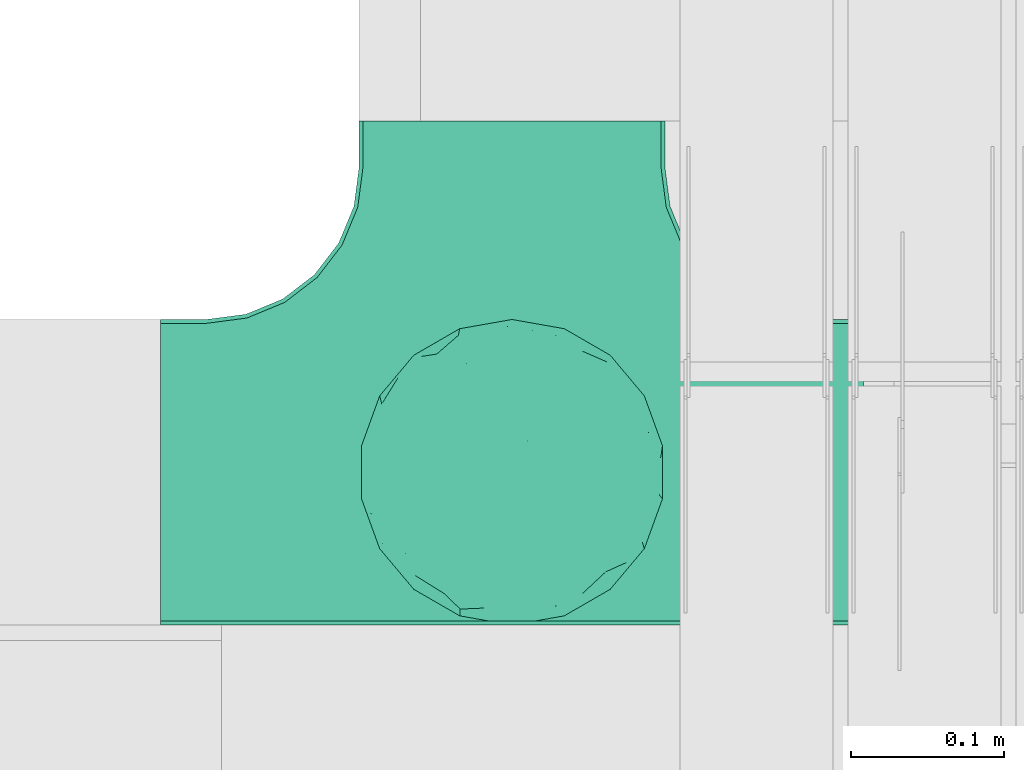
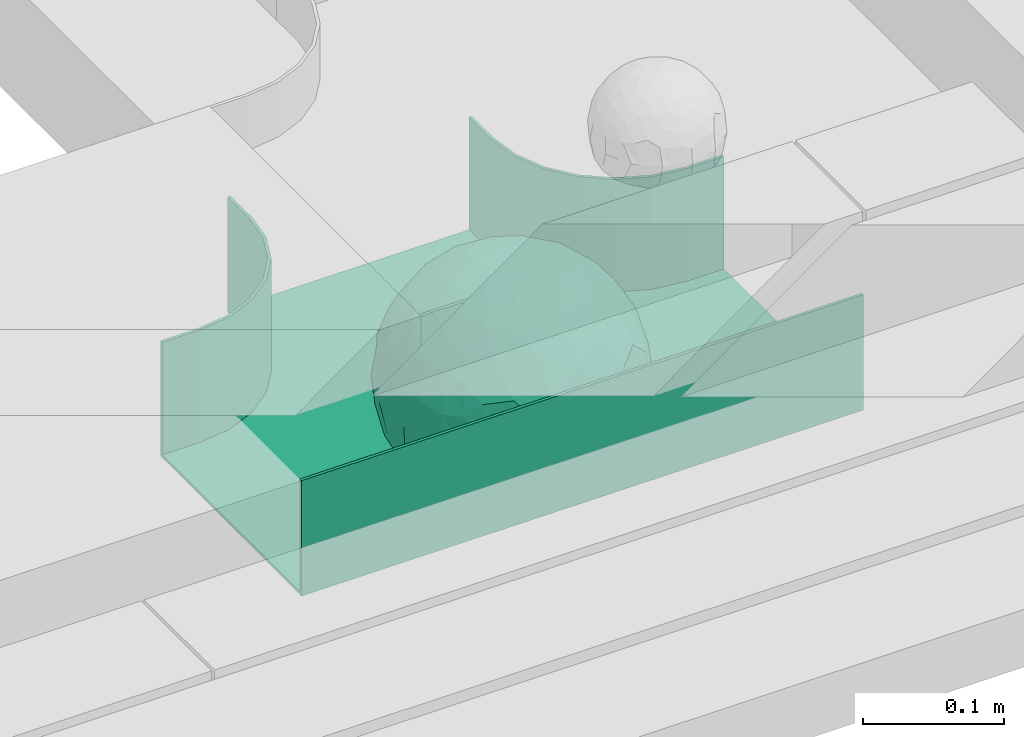
# One storey, part 31 of 33: 1 flow fitting.
"""IFC2X3 building model written with IfcOpenShell, lengths in millimetres."""

from ifc_helpers import new_model, entity, si_unit, converted_unit, derived_unit, direction, frame, origin, place, context, subcontext, project, spatial, faceted_brep, source, transform, mapped, material, material_list, type_object, type_shapes, element, save


model = new_model("IFC2X3")

# Units and contexts
model_context = context("Model", 3, precision=0.01, world=origin(), true_north=direction((6.12303176911189e-17, 1.0)))
body_context = subcontext(model_context, "Body", "Model", "MODEL_VIEW")
ifc_project = project(units=[si_unit("LENGTHUNIT", "METRE", prefix="MILLI"), si_unit("AREAUNIT", "SQUARE_METRE"), si_unit("VOLUMEUNIT", "CUBIC_METRE"), converted_unit("PLANEANGLEUNIT", "DEGREE", entity("IfcRatioMeasure", 0.0174532925199433), si_unit("PLANEANGLEUNIT", "RADIAN"), dimensions=[0, 0, 0, 0, 0, 0, 0]), si_unit("MASSUNIT", "GRAM", prefix="KILO"), derived_unit("MASSDENSITYUNIT", [(si_unit("MASSUNIT", "GRAM", prefix="KILO"), 1), (si_unit("LENGTHUNIT", "METRE"), -3)]), derived_unit("MOMENTOFINERTIAUNIT", [(si_unit("LENGTHUNIT", "METRE"), 4)]), si_unit("TIMEUNIT", "SECOND"), si_unit("FREQUENCYUNIT", "HERTZ"), si_unit("THERMODYNAMICTEMPERATUREUNIT", "DEGREE_CELSIUS"), derived_unit("THERMALTRANSMITTANCEUNIT", [(si_unit("MASSUNIT", "GRAM", prefix="KILO"), 1), (si_unit("THERMODYNAMICTEMPERATUREUNIT", "KELVIN"), -1), (si_unit("TIMEUNIT", "SECOND"), -3)]), derived_unit("VOLUMETRICFLOWRATEUNIT", [(si_unit("LENGTHUNIT", "METRE"), 3), (si_unit("TIMEUNIT", "SECOND"), -1)]), derived_unit("MASSFLOWRATEUNIT", [(si_unit("MASSUNIT", "GRAM", prefix="KILO"), 1), (si_unit("TIMEUNIT", "SECOND"), -1)]), derived_unit("ROTATIONALFREQUENCYUNIT", [(si_unit("TIMEUNIT", "SECOND"), -1)]), si_unit("ELECTRICCURRENTUNIT", "AMPERE"), si_unit("ELECTRICVOLTAGEUNIT", "VOLT"), si_unit("POWERUNIT", "WATT"), si_unit("FORCEUNIT", "NEWTON", prefix="KILO"), si_unit("ILLUMINANCEUNIT", "LUX"), si_unit("LUMINOUSFLUXUNIT", "LUMEN"), si_unit("LUMINOUSINTENSITYUNIT", "CANDELA"), derived_unit("USERDEFINED", [(si_unit("MASSUNIT", "GRAM", prefix="KILO"), -1), (si_unit("LENGTHUNIT", "METRE"), -2), (si_unit("TIMEUNIT", "SECOND"), 3), (si_unit("LUMINOUSFLUXUNIT", "LUMEN"), 1)]), derived_unit("LINEARVELOCITYUNIT", [(si_unit("LENGTHUNIT", "METRE"), 1), (si_unit("TIMEUNIT", "SECOND"), -1)]), si_unit("PRESSUREUNIT", "PASCAL"), derived_unit("USERDEFINED", [(si_unit("LENGTHUNIT", "METRE"), -2), (si_unit("MASSUNIT", "GRAM", prefix="KILO"), 1), (si_unit("TIMEUNIT", "SECOND"), -2)]), derived_unit("LINEARFORCEUNIT", [(si_unit("MASSUNIT", "GRAM", prefix="KILO"), 1), (si_unit("LENGTHUNIT", "METRE"), 1), (si_unit("TIMEUNIT", "SECOND"), -2), (si_unit("LENGTHUNIT", "METRE"), -1)]), derived_unit("PLANARFORCEUNIT", [(si_unit("MASSUNIT", "GRAM", prefix="KILO"), 1), (si_unit("LENGTHUNIT", "METRE"), 1), (si_unit("TIMEUNIT", "SECOND"), -2), (si_unit("LENGTHUNIT", "METRE"), -2)])], contexts=[model_context])

# Site, building, storey
site_placement = place(None, frame((0.0, -0.00077364408347762, 0.0)))
site = spatial("IfcSite", under=ifc_project, at=site_placement, CompositionType="ELEMENT")
building_placement = place(site_placement, origin())
building = spatial("IfcBuilding", under=site, at=building_placement, CompositionType="ELEMENT")
storey_placement = place(building_placement, frame((0.0, 0.0, 8100.0)))
storey = spatial("IfcBuildingStorey", under=building, at=storey_placement, CompositionType="ELEMENT", Elevation=8100.0)

# Flow fitting
ifc_material_1 = material()
ifc_material_2 = material()
ifc_material_list = material_list([ifc_material_1, ifc_material_2])
cable_carrier_fitting_type = type_object("IfcCableCarrierFittingType", PredefinedType="NOTDEFINED", material=ifc_material_1)
shared_shape = source(origin(), body_context, "Body", "Brep", [
    faceted_brep([(76.4840203203325, -37.7983376575012, -52.1678090968869), (89.2874188526836, -26.168482477916, -36.6465190629256), (85.270060821053, -46.6341564571094, -23.5429857730317), (-17.2892276551183, -34.784102350051, -92.1474298653505), (3.07548730030541e-06, -44.1611501073546, -89.7206376548624), (-24.6383925717335, -51.5777741549417, -82.0529269721827), (76.3287929967882, -15.079107031813, -62.8214604317408), (55.5757044674811, -29.5498647779489, -77.7055118028838), (-17.1010071662778, 96.9846310392869, 0.0), (-18.6742130440203, 88.8859886245005, -41.8396318510259), (-33.8953581705111, 89.5312614551001, -28.9008289976074), (-45.4623263334585, -10.4806178463803, -88.4496101399357), (-19.8193717281607, 5.04030654129894, -97.8866069197874), (-23.6628375063711, -16.1276312747485, -95.8121580521565), (92.5416578398381, 33.6824088833379, 0.0), (85.2767902974019, 45.7715256118899, -25.1562413673598), (86.6025403784496, 50.0, 0.0), (49.240387650616, -85.2868531952529, 0.0), (62.2001900548409, -72.1916708642314, -30.3232421580155), (64.2787609686595, -76.6044443119063, 0.0), (97.1714774391015, -8.71557429474411, -21.948638614181), (90.7615649771405, 0.0, -41.9802134689751), (96.1413151932242, 14.3969945426304, -23.4429959914917), (98.4807753012265, 17.3648177666844, 0.0), (98.4807753012265, 0.0, 0.0), (79.0119763428423, 8.47783312434252, -60.7061276965826), (76.4840203202329, 37.7983376578076, -52.1678090967986), (87.696722672108, 23.4364088603614, -41.9525871943713), (29.163429357778, -37.5977865113054, -87.9539699930814), (20.3014061890807, -63.7692165377112, -74.3057193553274), (-69.6223300212076, 53.192794202726, -48.2001847229044), (-47.2059268691477, 56.745965379315, -67.4647751170325), (-61.603837577254, 43.4748411443104, -65.6879394046569), (29.4497539748763, 71.3200718492295, -63.6094280923684), (47.2059306757939, 56.745965229418, -67.4647725795649), (30.0444734578003, 49.6507498561999, -81.4379067348793), (-49.6683382574198, -77.0947032728586, -39.8680687018642), (-34.202014332561, -93.9692620785994, 0.0), (-49.2403876506046, -85.2868531952529, 0.0), (61.3953921577507, 65.1440685107005, -44.5741647108287), (74.6816445462022, 59.1436972034819, -30.4084700203242), (61.9457748290475, 44.5417169664605, -64.6433015130544), (28.7737714324073, -89.42049207415, -34.2935223442239), (34.2020143325724, -93.9692620785994, 0.0), (25.6515107494307, -95.4769465589517, 0.0), (17.101007166289, -96.9846310393039, 0.0), (-64.2787609686481, -76.6044443119063, 0.0), (-75.4406506735431, -63.3022221559575, 0.0), (-74.7500995498228, -61.5460620722206, -24.9900952517949), (7.49675578587143, -83.6888268592038, -54.2215723823823), (36.4863653716413, -70.367842623822, -60.9681217230515), (-76.4840178500364, -37.798342255337, -52.1678093872333), (-87.0716088907139, -22.4880335791362, -43.7358350889169), (-79.0617266871127, -6.53517927425345, -60.8813173732629), (63.5329768828015, 0.0, -77.2240949989638), (-63.5329752663337, -4.28405924068898e-09, -77.2240963288374), (-81.9271917640341, 16.0413321025015, -55.0509846781547), (-98.4807753012151, -17.3648177667017, 0.0), (-95.569577544237, -17.0482102820805, -23.9961324840668), (-92.5416578398266, -33.6824088833551, 0.0), (65.8639795091221, 23.4057144961932, -71.5129969456177), (-19.2962502251216, 70.2650181304482, -68.487093341555), (-44.3250940555787, 79.4239687498613, -41.5586239543935), (-76.4840178487499, 37.7983422512769, -52.1678093920491), (-45.0467119602772, 37.358552492076, -81.0871894768975), (-67.1951546795767, 22.414876352536, -70.586007860525), (45.8905780821677, 15.5420810523434, -87.478560572553), (-67.1382383390432, -22.457587679949, -70.6265793333204), (-97.6852110527561, 5.09344694659685, -20.7763408659754), (-90.761561927752, 1.63062869873443e-09, -41.9802200617526), (-92.5416578398267, 33.6824088833379, 0.0), (-92.1520232806737, 27.1973992873941, -27.7183346772189), (28.8657365411401, 87.5169428696254, -38.8272322563751), (7.49675578553467, 83.6888268595355, -54.2215723818906), (1.22951801366171, 95.7251008343745, -28.8997120349128), (3.5162183498022, -95.8354910731824, -28.3406926393789), (-8.55050358313599, -98.4923155196562, 0.0), (-12.2828353145794, -96.1465810571431, -24.5960750457924), (75.4406506735547, 63.3022221559403, 0.0), (64.2787609686598, 76.6044443118892, 0.0), (75.4406506735545, -63.3022221559575, 0.0), (86.6025403784495, -50.0, 0.0), (-75.4406506735433, 63.3022221559403, 0.0), (-84.8930621241031, 46.8074333743426, -24.5404193953063), (-86.6025403784383, 50.0, 0.0), (-65.6229030223494, -61.3889655017833, -43.8751582736728), (-47.2059268729136, -56.7459653834318, -67.4647751109489), (-85.2400449211107, -44.6766589600176, -27.1685642980393), (46.0205786918846, 37.1654843094529, -80.6277440643515), (-63.1788213480048, 67.6783588085196, -37.7898965605855), (-7.15444733827542, -67.6177156734158, -73.3257008857939), (31.5424765006817, -5.30265693589207, -94.7467888934671), (9.84735642755859, -20.4964224402077, -97.3803175109847), (1.0083019663368e-06, 13.3030981775211, -99.111187960177), (49.3513473168359, -11.1781440260195, -86.252499176233), (92.541657839838, -33.6824088833551, 0.0), (98.4807753012265, -17.3648177667017, 0.0), (49.2403876506163, 85.2868531952358, 0.0), (46.4041236261553, 79.1080859305986, -39.8568444672194), (34.2020143325727, 93.9692620785823, 0.0), (-53.1130236264114, 15.1205787052499, -83.3689079985849), (64.5322070769988, -54.17210261472, -53.8607236125959), (47.2059306758545, -56.745965228813, -67.4647725800455), (22.8875622085795, 27.5743091168824, -93.3585399032859), (74.6816445462803, -59.1436972033529, -30.4084700204161), (46.4041236262572, -79.108085930386, -39.8568444675565), (-15.7383008676665, 23.1933977335444, -95.9915214348144), (2.80963889519618, 33.9846447662373, -94.0061160211894), (9.20690877800443, 52.3900236205866, -84.6789126984153), (9.72607601259755, 69.7500364970203, -70.995322761851), (17.1010071662892, 96.9846310392869, 0.0), (-5.62154210059744, -90.1648531765776, -42.8800363346189), (0.0, -100.0, 0.0), (-25.1293295965289, -93.3686387308287, -25.5110582999201), (-25.949186528859, -84.8833009001169, -46.0593632912046), (-17.1010071662777, -96.9846310393039, 0.0), (-10.2354907319271, -80.7824512711375, -58.0467940208873), (-31.237630661844, -69.7640997378305, -64.4762035048911), (-42.1850269133029, -33.6354441712551, -84.1966768924114), (-35.781529361024, 18.547890266457, -91.5186206367184), (-61.619736792185, -43.523827571712, -65.6405703141646), (-17.3443611696694, 40.8888850191612, -89.595045719636), (-29.1001411816516, 55.690814260002, -77.7927695243168), (-10.6569193640809, 57.0342754657797, -81.4464332660353), (-59.774866149928, -75.5723898452015, -26.7540514659609), (-86.6025403784381, -50.0, 0.0), (-98.4807753012151, 0.0, 0.0), (-98.4807753012152, 17.3648177666844, 0.0), (-74.7670053246598, 60.7049605869996, -26.9221595513964), (-64.2787609686484, 76.6044443118892, 0.0), (-49.2403876506049, 85.2868531952358, 0.0), (-34.2020143325614, 93.9692620785823, 0.0), (0.0, 100.0, 0.0), (-76.484019526794, -37.798337198235, 52.1678105930665), (-89.2874185112873, -26.1684825046027, 36.6465198756512), (-85.2700607126513, -46.6341564521743, 23.5429861753997), (17.2892307880813, -34.7841011602588, 92.1474297266695), (-3.38734512270379e-07, -44.1611496359296, 89.720637886916), (24.6383956411536, -51.5777728113463, 82.0529268951053), (-76.3287917934888, -15.0791068021182, 62.8214619488982), (-55.5757026100472, -29.549864599369, 77.7055131992549), (18.6742091034424, 88.885990914275, 41.8396287453374), (33.8953586129312, 89.5312597468659, 28.9008337706599), (17.3443607633453, 40.8888810970192, 89.5950475882768), (15.7383028761951, 23.1933956687767, 95.9915216044101), (35.7815318404767, 18.5478901047313, 91.5186197001092), (-85.2767901734143, 45.7715256234335, 25.1562417666364), (-62.2001897574699, -72.1916707653145, 30.3232430034808), (-97.1714773187454, -8.71557427953189, 21.9486391530291), (-96.141315013212, 14.3969947624817, 23.4429965946852), (-79.0119753418501, 8.47783306286876, 60.7061290080075), (-76.4840195267832, 37.7983371982528, 52.1678105930571), (-87.6967222099395, 23.4364087722604, 41.9525882096856), (-29.163427099677, -37.5977868949179, 87.9539705778413), (-20.301404034393, -63.7692173365967, 74.305719258427), (69.6223307049661, 53.192787114506, 48.2001915577083), (47.2059293170501, 56.7459646829409, 67.4647739899622), (61.6038389573326, 43.4748357207471, 65.6879416999347), (-61.3953919237905, 65.1440676388516, 44.5741663072653), (49.2659552585237, -77.3488009806731, 39.8751631886295), (-74.681644350378, 59.1436969740875, 30.4084709474116), (-61.9457736264423, 44.5417164806275, 64.643303000237), (-7.49675472945651, -83.6888265867081, 54.2215729490431), (-36.486364416374, -70.367842442625, 60.968122503872), (-28.7737710558201, -89.4204919730988, 34.2935229236939), (74.7446466999101, -61.6521905333982, 24.7435889098862), (3.00446277704405, -95.5180690083503, 29.4494770130044), (-13.4675721353261, -92.748406770264, 34.876317786707), (76.4840204055964, -37.7983390347103, 52.167807974034), (87.0716107179514, -22.4880293497667, 43.7358336258448), (79.0617298359488, -6.53517466347878, 60.8813137790831), (-63.5329751791014, 0.0, 77.2240964006191), (63.5329772594296, 0.0, 77.2240946891232), (81.9271971902465, 16.0413321407425, 55.050976591722), (95.5695783977716, -17.0482115223089, 23.9961282036192), (-65.8639781491499, 23.405714160557, 71.5129983080176), (19.2962569358552, 70.2650237882598, 68.4870856461333), (44.3251010195622, 79.4239674638786, 41.5586189845396), (76.4840204055789, 37.7983390346199, 52.1678079741129), (45.0467113579588, 37.35855313631, 81.0871895147151), (67.1951616703757, 22.4148716107117, 70.5860027113649), (-45.8905758090763, 15.5420810346383, 87.4785617681537), (67.1382437930653, -22.4575840893256, 70.6265752904385), (97.6852138116852, 5.09344112492882, 20.7763293214556), (90.7615650780775, 0.0, 41.9802132507632), (92.1520274335419, 27.1973943799444, 27.7183256859159), (-28.8657360653296, 87.5169427229152, 38.8272329408042), (-7.49675472951015, 83.6888265867653, 54.2215729489213), (-1.22952463606755, 95.725101063195, 28.8997109952541), (7.15445060231028, -67.6177152767913, 73.3257009330848), (30.0445391888188, -71.0236195697132, 63.6629494144802), (-90.7615645164956, 0.0, 41.9802144648834), (84.8930644946618, 46.8074299509675, 24.5404177244603), (65.657396767693, -61.8519680594647, 43.1675838664051), (47.2059293174508, -56.7459646832734, 67.4647739894163), (85.240045822543, -44.6766582374337, 27.1685626581248), (-30.0444712047215, 49.6507502843406, 81.4379073050796), (-47.2059295896367, 56.7459650911412, 67.4647734558766), (-46.0205764805425, 37.1654842487523, 80.6277453545262), (63.1788267861392, 67.6783521071165, 37.7898994705241), (-31.542473908998, -5.30265693887445, 94.7467897561175), (-9.84735391303847, -20.4964227184575, 97.3803177067078), (1.34873765353802e-06, 13.3030991109957, 99.1111878348972), (-49.3513452292634, -11.1781439777262, 86.2525003769525), (-46.4041232356316, 79.1080858261746, 39.8568451291574), (-29.4497536788485, 71.3200715314942, 63.609428585683), (24.3100719261245, -93.7923353358836, 24.7390023078953), (-64.5322063997089, -54.1721023527289, 53.8607246875848), (-47.2059295895764, -56.7459650910276, 67.4647734560286), (-22.8875602129064, 27.5743087068143, 93.3585405136699), (-46.4041232356225, -79.1080858261415, 39.8568451292672), (-74.6816443503883, -59.1436969740864, 30.408470947421), (19.8193741532226, 5.04030693924503, 97.8866064083047), (-2.80963679644177, 33.9846454726014, 94.0061158285697), (-9.20690598859987, 52.3900245858364, 84.6789124045226), (-9.72607582248976, 69.7500367089908, 70.9953225796557), (9.6507963138497, -80.5368358032807, 58.4865814465705), (23.4705761898964, -86.311306248728, 44.7156624344864), (35.1118074315221, -89.6215726748419, 27.113367370765), (42.1850318693192, -33.6354421467953, 84.1966752180655), (23.6628407100174, -16.1276300406404, 95.8121574686978), (45.4623290073054, -10.4806171517165, 88.4496088479348), (61.6197386049218, -43.5238234805734, 65.6405713251752), (29.1001407425045, 55.6908137196801, 77.7927700754181), (10.6569061579526, 57.0342796833114, 81.4464320406166), (59.3537179746501, -75.8188405832575, 26.9933246414488), (74.7670061544982, 60.7049632941286, 26.9221511427291), (53.1130277137063, 15.1205817594398, 83.3689048407183)], [[[0, 1, 2]], [[3, 4, 5]], [[6, 0, 7]], [[8, 9, 10]], [[11, 12, 13]], [[14, 15, 16]], [[17, 18, 19]], [[20, 21, 22]], [[22, 23, 24]], [[25, 26, 27]], [[4, 28, 29]], [[30, 31, 32]], [[33, 34, 35]], [[36, 37, 38]], [[39, 40, 41]], [[42, 43, 44, 45]], [[46, 47, 48]], [[49, 50, 42]], [[51, 52, 53]], [[54, 25, 6]], [[55, 53, 56]], [[57, 58, 59]], [[26, 25, 60]], [[61, 31, 62]], [[32, 63, 30]], [[64, 65, 32]], [[54, 66, 60]], [[53, 67, 51]], [[58, 68, 69]], [[68, 70, 71]], [[72, 73, 74]], [[75, 76, 77]], [[6, 7, 54]], [[24, 20, 22]], [[78, 40, 79]], [[15, 26, 40]], [[1, 21, 20]], [[80, 2, 81]], [[63, 56, 71]], [[82, 83, 84]], [[36, 85, 86]], [[87, 58, 52]], [[35, 34, 88]], [[62, 31, 89]], [[42, 75, 49]], [[4, 29, 90]], [[91, 92, 93]], [[7, 94, 54]], [[6, 1, 0]], [[95, 81, 2]], [[24, 96, 20]], [[1, 20, 95]], [[1, 95, 2]], [[27, 22, 21]], [[15, 14, 22]], [[25, 27, 21]], [[15, 78, 16]], [[41, 40, 26]], [[40, 78, 15]], [[39, 97, 79]], [[97, 98, 99]], [[40, 39, 79]], [[33, 73, 72]], [[21, 1, 6]], [[25, 54, 60]], [[64, 100, 65]], [[26, 15, 27]], [[6, 25, 21]], [[0, 101, 7]], [[102, 28, 7]], [[92, 91, 28]], [[94, 28, 91]], [[88, 34, 41]], [[54, 94, 66]], [[41, 26, 60]], [[103, 91, 93]], [[88, 41, 60]], [[20, 96, 95]], [[101, 18, 102]], [[104, 80, 19]], [[101, 0, 104]], [[18, 105, 102]], [[43, 42, 105]], [[17, 43, 105]], [[29, 28, 102]], [[28, 4, 92]], [[105, 50, 102]], [[90, 29, 49]], [[88, 60, 66]], [[41, 34, 39]], [[34, 98, 39]], [[97, 39, 98]], [[103, 66, 91]], [[88, 66, 103]], [[12, 106, 93]], [[33, 98, 34]], [[107, 103, 93]], [[35, 103, 108]], [[103, 35, 88]], [[33, 109, 73]], [[109, 35, 108]], [[110, 72, 74]], [[72, 110, 99]], [[98, 33, 72]], [[99, 98, 72]], [[80, 104, 2]], [[0, 2, 104]], [[101, 104, 18]], [[7, 101, 102]], [[19, 18, 104]], [[105, 18, 17]], [[77, 111, 75]], [[75, 45, 112]], [[113, 114, 111]], [[115, 77, 76]], [[36, 114, 37]], [[90, 5, 4]], [[75, 42, 45]], [[50, 49, 29]], [[49, 116, 90]], [[5, 117, 86]], [[90, 116, 117]], [[118, 13, 3]], [[118, 5, 86]], [[11, 119, 12]], [[67, 120, 51]], [[11, 13, 118]], [[65, 55, 56]], [[121, 122, 123]], [[90, 117, 5]], [[51, 120, 85]], [[117, 36, 86]], [[36, 117, 114]], [[46, 48, 124]], [[38, 124, 36]], [[85, 124, 48]], [[87, 125, 59]], [[125, 87, 47]], [[48, 51, 85]], [[68, 57, 126, 127]], [[59, 58, 87]], [[58, 69, 52]], [[53, 52, 69]], [[87, 52, 51]], [[56, 53, 69]], [[53, 55, 67]], [[71, 56, 69]], [[56, 63, 65]], [[71, 69, 68]], [[128, 129, 89]], [[11, 67, 55]], [[120, 118, 86]], [[32, 65, 63]], [[100, 55, 65]], [[118, 120, 67]], [[85, 120, 86]], [[129, 128, 82]], [[64, 32, 31]], [[62, 130, 131]], [[130, 62, 89]], [[9, 73, 61]], [[10, 62, 131]], [[109, 61, 73]], [[73, 9, 74]], [[64, 121, 119]], [[122, 61, 123]], [[64, 119, 100]], [[64, 31, 122]], [[107, 108, 103]], [[47, 87, 48]], [[51, 48, 87]], [[57, 68, 58]], [[64, 122, 121]], [[89, 129, 130]], [[67, 11, 118]], [[11, 55, 100]], [[82, 128, 83]], [[30, 128, 89]], [[83, 63, 71]], [[63, 83, 128]], [[84, 83, 71]], [[10, 61, 62]], [[74, 8, 132]], [[8, 74, 9]], [[110, 74, 132]], [[3, 92, 4]], [[92, 13, 12]], [[22, 27, 15]], [[14, 23, 22]], [[11, 100, 119]], [[128, 30, 63]], [[31, 30, 89]], [[28, 94, 7]], [[66, 94, 91]], [[42, 50, 105]], [[29, 102, 50]], [[106, 107, 93]], [[123, 107, 121]], [[35, 109, 33]], [[109, 108, 123]], [[75, 112, 76]], [[113, 77, 115]], [[114, 116, 111]], [[115, 37, 113]], [[37, 114, 113]], [[49, 75, 111]], [[117, 116, 114]], [[111, 77, 113]], [[49, 111, 116]], [[118, 3, 5]], [[92, 3, 13]], [[106, 119, 121]], [[92, 12, 93]], [[119, 106, 12]], [[107, 106, 121]], [[46, 124, 38]], [[85, 36, 124]], [[70, 68, 127]], [[70, 84, 71]], [[31, 61, 122]], [[109, 123, 61]], [[107, 123, 108]], [[8, 10, 131]], [[61, 10, 9]], [[133, 134, 135]], [[136, 137, 138]], [[139, 133, 140]], [[110, 141, 142]], [[143, 144, 145]], [[70, 146, 84]], [[38, 147, 46]], [[126, 57, 148]], [[149, 127, 126]], [[150, 151, 152]], [[137, 153, 154]], [[155, 156, 157]], [[130, 129, 158]], [[159, 43, 17]], [[158, 160, 161]], [[162, 163, 164]], [[19, 80, 165]], [[166, 167, 115]], [[168, 169, 170]], [[171, 150, 139]], [[172, 170, 173]], [[96, 174, 95]], [[151, 150, 175]], [[176, 156, 177]], [[157, 178, 155]], [[179, 180, 157]], [[171, 181, 175]], [[170, 182, 168]], [[174, 183, 184]], [[185, 23, 14, 16]], [[186, 187, 188]], [[138, 189, 190]], [[139, 140, 171]], [[126, 148, 149]], [[82, 160, 129]], [[146, 151, 160]], [[134, 191, 148]], [[47, 135, 125]], [[178, 173, 185]], [[78, 192, 16]], [[159, 193, 194]], [[195, 174, 169]], [[196, 197, 198]], [[177, 156, 199]], [[166, 112, 45]], [[154, 189, 137]], [[200, 201, 202]], [[140, 203, 171]], [[191, 149, 148]], [[59, 125, 135]], [[133, 139, 134]], [[134, 148, 59]], [[134, 59, 135]], [[152, 149, 191]], [[146, 70, 149]], [[150, 152, 191]], [[146, 82, 84]], [[161, 160, 151]], [[160, 82, 146]], [[204, 131, 130]], [[186, 205, 187]], [[160, 158, 129]], [[197, 196, 205]], [[191, 134, 139]], [[150, 171, 175]], [[45, 206, 166]], [[151, 146, 152]], [[139, 150, 191]], [[133, 207, 140]], [[208, 153, 140]], [[201, 200, 153]], [[203, 153, 200]], [[198, 197, 161]], [[171, 203, 181]], [[161, 151, 175]], [[209, 200, 202]], [[198, 161, 175]], [[148, 57, 59]], [[38, 37, 210]], [[211, 47, 46]], [[207, 133, 211]], [[147, 210, 208]], [[210, 37, 164]], [[208, 207, 147]], [[154, 153, 208]], [[153, 137, 201]], [[210, 163, 208]], [[189, 154, 162]], [[198, 175, 181]], [[161, 197, 158]], [[197, 204, 158]], [[130, 158, 204]], [[209, 181, 200]], [[198, 181, 209]], [[212, 144, 202]], [[205, 204, 197]], [[213, 209, 202]], [[196, 209, 214]], [[209, 196, 198]], [[205, 215, 187]], [[215, 196, 214]], [[8, 186, 188]], [[186, 8, 131]], [[204, 205, 186]], [[131, 204, 186]], [[47, 211, 135]], [[133, 135, 211]], [[207, 211, 147]], [[140, 207, 208]], [[46, 147, 211]], [[210, 147, 38]], [[166, 115, 76, 112]], [[115, 164, 37]], [[163, 162, 154]], [[216, 166, 217]], [[138, 137, 189]], [[162, 216, 189]], [[218, 44, 43]], [[44, 218, 206]], [[189, 216, 190]], [[219, 220, 136]], [[219, 138, 194]], [[221, 145, 212]], [[182, 222, 168]], [[221, 220, 219]], [[180, 172, 173]], [[143, 223, 224]], [[168, 222, 193]], [[194, 138, 190]], [[190, 159, 194]], [[190, 217, 218]], [[19, 165, 225]], [[17, 225, 159]], [[193, 225, 165]], [[195, 81, 95]], [[81, 195, 80]], [[165, 168, 193]], [[183, 96, 24, 23]], [[95, 174, 195]], [[174, 184, 169]], [[170, 169, 184]], [[195, 169, 168]], [[173, 170, 184]], [[170, 172, 182]], [[185, 173, 184]], [[173, 178, 180]], [[185, 184, 183]], [[226, 79, 199]], [[221, 182, 172]], [[222, 219, 194]], [[157, 180, 178]], [[227, 172, 180]], [[219, 222, 182]], [[193, 222, 194]], [[79, 226, 78]], [[179, 157, 156]], [[177, 97, 99]], [[97, 177, 199]], [[141, 187, 176]], [[142, 177, 99]], [[215, 176, 187]], [[187, 141, 188]], [[179, 143, 145]], [[223, 176, 224]], [[179, 145, 227]], [[179, 156, 223]], [[213, 214, 209]], [[96, 183, 174]], [[185, 183, 23]], [[80, 195, 165]], [[168, 165, 195]], [[199, 79, 97]], [[182, 221, 219]], [[221, 172, 227]], [[78, 226, 192]], [[155, 226, 199]], [[192, 178, 185]], [[178, 192, 226]], [[16, 192, 185]], [[142, 176, 177]], [[188, 110, 132]], [[110, 188, 141]], [[8, 188, 132]], [[136, 201, 137]], [[201, 220, 212]], [[149, 152, 146]], [[70, 127, 149]], [[167, 162, 164]], [[179, 227, 180]], [[221, 227, 145]], [[226, 155, 178]], [[156, 155, 199]], [[153, 203, 140]], [[181, 203, 200]], [[164, 163, 210]], [[154, 208, 163]], [[144, 213, 202]], [[224, 213, 143]], [[196, 215, 205]], [[215, 214, 224]], [[166, 216, 162]], [[190, 216, 217]], [[218, 217, 206]], [[43, 159, 218]], [[190, 218, 159]], [[166, 206, 217]], [[44, 206, 45]], [[219, 136, 138]], [[201, 136, 220]], [[201, 212, 202]], [[221, 212, 220]], [[145, 144, 212]], [[213, 144, 143]], [[19, 225, 17]], [[193, 159, 225]], [[179, 223, 143]], [[156, 176, 223]], [[215, 224, 176]], [[213, 224, 214]], [[110, 142, 99]], [[176, 142, 141]], [[115, 167, 164]], [[166, 162, 167]]]),
    faceted_brep([(-103.407417371086, -174.118095489752, 50.0), (-100.0, -200.0, 50.0), (-100.0, -230.0, 50.0), (-97.4600000101529, -230.0, 50.0), (-97.4600000101529, -200.0, 50.0), (-100.953965782126, -173.460695117822, 50.0), (-111.197755104736, -148.730000005084, 50.0), (-127.49327066431, -127.493270664319, 50.0), (-148.730000005075, -111.197755104746, 50.0), (-173.460695117813, -100.953965782136, 50.0), (-200.0, -97.4600000101643, 50.0), (-230.0, -97.4600000101643, 50.0), (-230.0, -100.0, 50.0), (-200.0, -100.0, 50.0), (-174.118095489745, -103.407417371098, 50.0), (-150.0, -113.39745962156, 50.0), (-129.28932188134, -129.289321881349, 50.0), (-113.39745962155, -150.0, 50.0), (230.0, -100.0, 50.0), (230.0, -97.4600000101643, 50.0), (200.0, -97.4600000101643, 50.0), (173.460695117866, -100.953965782136, 50.0), (148.730000005124, -111.197755104745, 50.0), (127.493270664353, -127.493270664316, 50.0), (111.197755104772, -148.730000005079, 50.0), (100.953965782152, -173.460695117816, 50.0), (97.4600000101669, -200.0, 50.0), (97.4600000101669, -230.0, 50.0), (100.0, -230.0, 50.0), (100.0, -200.0, 50.0), (103.40741737111, -174.118095489747, 50.0), (113.397459621584, -150.0, 50.0), (129.289321881382, -129.289321881346, 50.0), (150.0, -113.397459621558, 50.0), (174.118095489797, -103.407417371097, 50.0), (200.0, -100.0, 50.0), (230.0, 97.4600000101552, 50.0), (230.0, 100.0, 50.0), (-230.0, 100.0, 50.0), (-230.0, 97.4600000101552, 50.0), (-230.0, -100.0, -50.0), (-230.0, 100.0, -50.0), (230.0, 100.0, -50.0), (230.0, -100.0, -50.0), (200.0, -100.0, -50.0), (174.118095489797, -103.407417371097, -50.0), (150.0, -113.397459621558, -50.0), (129.289321881382, -129.289321881346, -50.0), (113.397459621584, -150.0, -50.0), (103.40741737111, -174.118095489747, -50.0), (100.0, -200.0, -50.0), (100.0, -230.0, -50.0), (-100.0, -230.0, -50.0), (-100.0, -200.0, -50.0), (-103.407417371086, -174.118095489752, -50.0), (-113.39745962155, -150.0, -50.0), (-129.28932188134, -129.289321881349, -50.0), (-150.0, -113.39745962156, -50.0), (-174.118095489745, -103.407417371098, -50.0), (-200.0, -100.0, -50.0), (-100.0, -200.0, -47.4600000101619), (97.4600000101669, -230.0, -47.4600000101619), (-97.4600000101529, -230.0, -47.4600000101619), (-97.4600000101529, -200.0, -47.4600000101619), (-200.0, -97.4600000101643, -47.4600000101619), (-230.0, -97.4600000101643, -47.4600000101619), (230.0, -97.4600000101643, -47.4600000101619), (200.0, -97.4600000101643, -47.4600000101619), (-230.0, 97.4600000101552, -47.4600000101619), (-200.0, -100.0, -47.4600000101619), (200.0, -100.0, -47.4600000101619), (230.0, 97.4600000101552, -47.4600000101619), (97.4600000101669, -200.0, -47.4600000101619), (100.0, -200.0, -47.4600000101619), (-173.460695117813, -100.953965782136, -47.4600000101619), (-148.730000005075, -111.197755104746, -47.4600000101619), (-127.49327066431, -127.493270664319, -47.4600000101619), (-111.197755104736, -148.730000005084, -47.4600000101619), (-100.953965782126, -173.460695117822, -47.4600000101619), (100.953965782151, -173.460695117817, -47.4600000101619), (111.197755104771, -148.73000000508, -47.4600000101619), (127.493270664353, -127.493270664317, -47.4600000101619), (148.730000005123, -111.197755104745, -47.4600000101619), (173.460695117865, -100.953965782137, -47.4600000101619)], [[[0, 1, 2, 3, 4, 5, 6, 7, 8, 9, 10, 11, 12, 13, 14, 15, 16, 17]], [[18, 19, 20, 21, 22, 23, 24, 25, 26, 27, 28, 29, 30, 31, 32, 33, 34, 35]], [[36, 37, 38, 39]], [[40, 41, 42, 43, 44, 45, 46, 47, 48, 49, 50, 51, 52, 53, 54, 55, 56, 57, 58, 59]], [[2, 1, 60, 53, 52]], [[3, 2, 52, 51, 28, 27, 61, 62]], [[4, 3, 62, 63]], [[11, 10, 64, 65]], [[20, 19, 66, 67]], [[39, 38, 41, 40, 12, 11, 65, 68]], [[13, 12, 40, 59, 69]], [[18, 35, 70, 44, 43]], [[19, 18, 43, 42, 37, 36, 71, 66]], [[27, 26, 72, 61]], [[29, 28, 51, 50, 73]], [[38, 37, 42, 41]], [[36, 39, 68, 71]], [[68, 65, 64, 74, 75, 76, 77, 78, 63, 62, 61, 72, 79, 80, 81, 82, 83, 67, 66, 71]], [[14, 13, 69, 59, 58]], [[15, 14, 58, 57]], [[57, 56, 16, 15]], [[17, 16, 56, 55]], [[0, 17, 55, 54]], [[1, 0, 54, 53, 60]], [[5, 78, 77, 6]], [[6, 77, 76, 7]], [[63, 78, 5, 4]], [[8, 75, 74, 9]], [[9, 74, 64, 10]], [[7, 76, 75, 8]], [[21, 83, 82, 22]], [[22, 82, 81, 23]], [[67, 83, 21, 20]], [[24, 80, 79, 25]], [[25, 79, 72, 26]], [[23, 81, 80, 24]], [[30, 29, 73, 50, 49]], [[31, 30, 49, 48]], [[32, 31, 48, 47]], [[34, 33, 46, 45]], [[34, 45, 44, 70, 35]], [[46, 33, 32, 47]]]),
])
type_shapes(cable_carrier_fitting_type, [shared_shape])
flow_fitting_placement = place(storey_placement, frame((60360.1085349486, 9069.97860618816, 2599.83876380786), z_axis=(0.0, 0.0, 1.0), x_axis=(-1.0, 0.0, 0.0)))
element("IfcFlowFitting", 1, at=flow_fitting_placement, inside=storey, type_object=cable_carrier_fitting_type, material=ifc_material_list, Name="470_DKC_S5_T", context=body_context, shape_type="MappedRepresentation", body=[
    mapped(shared_shape, transform((0.0, 0.0, 0.0), scale=1.0)),
])

save(model, "model.ifc")
